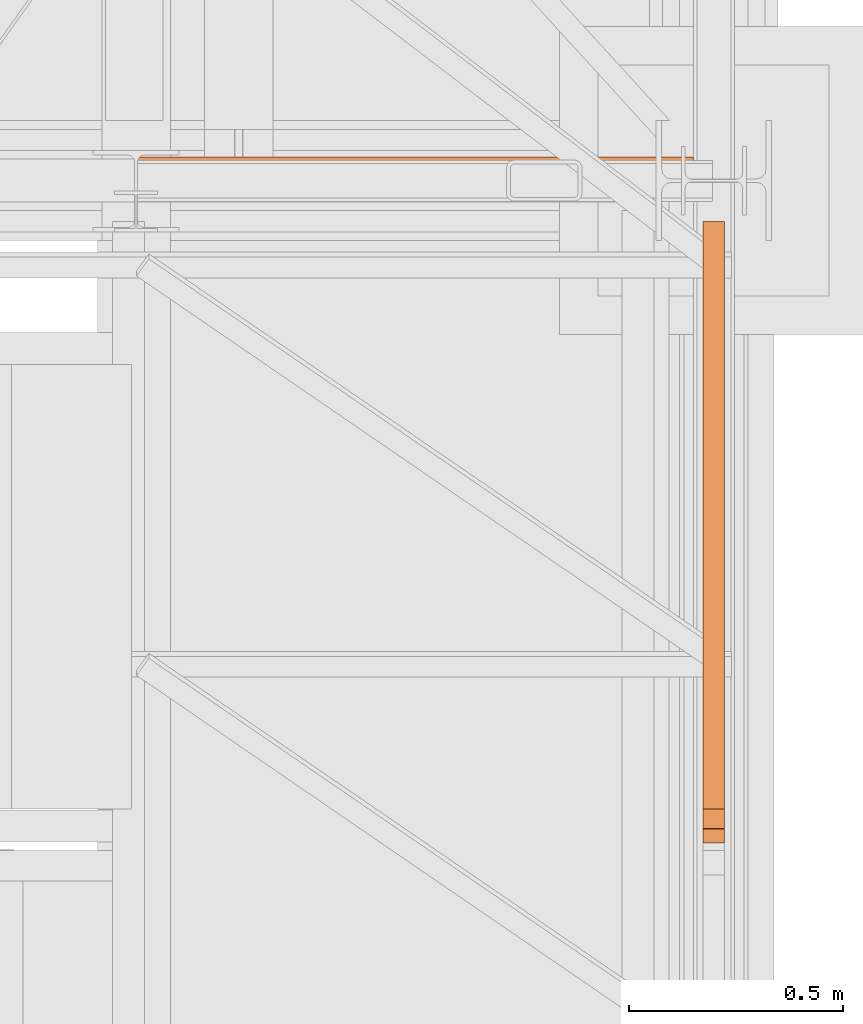
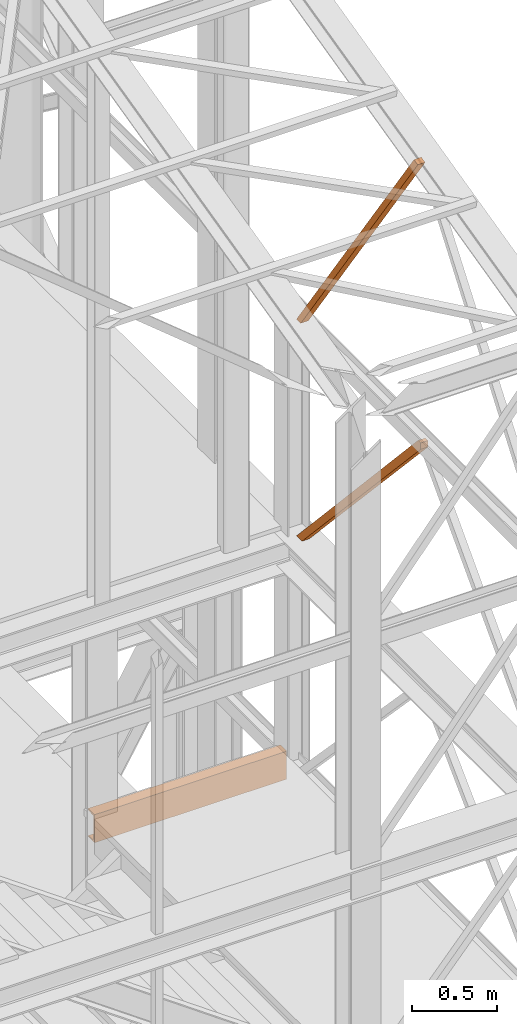
# One storey, part 59 of 208: 4 proxies.
"""IFC2X3 building model written with IfcOpenShell, lengths in millimetres."""

from ifc_helpers import new_model, entity, si_unit, converted_unit, frame, origin, origin_with_axes, place, context, subcontext, project, spatial, faceted_brep, element, save


model = new_model("IFC2X3")

# Units and contexts
model_context = context("Model", 3, precision=1e-05, world=origin())
plan_context = context("Plan", 3, precision=1e-05, world=origin())
body_context = subcontext(model_context, "Body", "Model", "MODEL_VIEW")
ifc_project = project(units=[si_unit("LENGTHUNIT", "METRE", prefix="MILLI"), converted_unit("PLANEANGLEUNIT", "DEGREE", entity("IfcPlaneAngleMeasure", 0.0174532925199433), si_unit("PLANEANGLEUNIT", "RADIAN"), dimensions=[0, 0, 0, 0, 0, 0, 0]), si_unit("AREAUNIT", "SQUARE_METRE"), si_unit("VOLUMEUNIT", "CUBIC_METRE")], contexts=[model_context, plan_context])

# Building, storey
building_placement = place(None, origin())
building = spatial("IfcBuilding", under=ifc_project, at=building_placement, CompositionType="COMPLEX")
storey_placement = place(building_placement, origin_with_axes())
storey = spatial("IfcBuildingStorey", under=building, at=storey_placement, Name="Geschoss", CompositionType="ELEMENT")

# Proxies
proxy_1_placement = place(storey_placement, frame((5351.50496859572, -22082.72083116692, 6709.989998509885), z_axis=(0.0, 0.0, 1.0), x_axis=(1.0, 0.0, 0.0)))
element("IfcBuildingElementProxy", 1, at=proxy_1_placement, inside=storey, context=body_context, shape_type="Brep", body=[
    faceted_brep([(0.01000000000021828, 0.00999999999839929, 200.0100029802325), (0.01000000000021828, 0.00999999999839929, 0.01000000000021828), (0.01000000000021828, 75.01000111758549, 0.01000000000021828), (0.01000000000021828, 75.01000111758549, 2.97083092689536), (0.01000000000021828, 73.89400100171406, 7.368834147453526), (0.01000000000021828, 69.488472694753, 8.951724896431188), (0.01000000000021828, 19.09293180167515, 12.98336816787742), (0.01000000000021828, 13.35380079060633, 14.57858962774299), (0.01000000000021828, 9.500150026975462, 18.85888857603095), (0.01000000000021828, 8.510000461934396, 24.44674206733725), (0.01000000000021828, 8.510000461934396, 175.5732609128954), (0.01000000000021828, 9.500150026975462, 181.1611144042017), (0.01000000000021828, 13.35380079060633, 185.4414133524897), (0.01000000000021828, 19.09293180167515, 187.0366348123553), (0.01000000000021828, 69.488472694753, 191.0682780838015), (0.01000000000021828, 73.89400100171406, 192.6511688327792), (0.01000000000021828, 75.01000111758549, 197.0491720533373), (0.01000000000021828, 75.01000111758549, 200.0100029802325), (0.01000000000021828, 0.00999999999839929, 0.01000000000021828), (0.01000000000021828, 0.00999999999839929, 200.0100029802325), (1298.7599995485, 0.00999999999839929, 200.0100029802325), (1298.7599995485, 0.00999999999839929, 0.01000000000021828), (0.01000000000021828, 75.01000111758549, 0.01000000000021828), (0.01000000000021828, 0.00999999999839929, 0.01000000000021828), (1298.7599995485, 0.00999999999839929, 0.01000000000021828), (1298.7599995485, 75.01000111758549, 0.01000000000021828), (0.01000000000021828, 75.01000111758549, 2.97083092689536), (0.01000000000021828, 75.01000111758549, 0.01000000000021828), (1298.7599995485, 75.01000111758549, 0.01000000000021828), (1298.7599995485, 75.01000111758549, 2.97083092689536), (0.01000000000021828, 73.89400100171406, 7.368834147453526), (0.01000000000021828, 75.01000111758549, 2.97083092689536), (1298.7599995485, 75.01000111758549, 2.97083092689536), (1298.7599995485, 73.89400100171406, 7.368834147453526), (0.01000000000021828, 69.488472694753, 8.951724896431188), (0.01000000000021828, 73.89400100171406, 7.368834147453526), (1298.7599995485, 73.89400100171406, 7.368834147453526), (1298.7599995485, 69.488472694753, 8.951724896431188), (0.01000000000021828, 19.09293180167515, 12.98336816787742), (0.01000000000021828, 69.488472694753, 8.951724896431188), (1298.7599995485, 69.488472694753, 8.951724896431188), (1298.7599995485, 19.09293180167515, 12.98336816787742), (0.01000000000021828, 13.35380079060633, 14.57858962774299), (0.01000000000021828, 19.09293180167515, 12.98336816787742), (1298.7599995485, 19.09293180167515, 12.98336816787742), (1298.7599995485, 13.35380079060633, 14.57858962774299), (0.01000000000021828, 9.500150026975462, 18.85888857603095), (0.01000000000021828, 13.35380079060633, 14.57858962774299), (1298.7599995485, 13.35380079060633, 14.57858962774299), (1298.7599995485, 9.500150026975462, 18.85888857603095), (0.01000000000021828, 8.510000461934396, 24.44674206733725), (0.01000000000021828, 9.500150026975462, 18.85888857603095), (1298.7599995485, 9.500150026975462, 18.85888857603095), (1298.7599995485, 8.510000461934396, 24.44674206733725), (0.01000000000021828, 8.510000461934396, 175.5732609128954), (0.01000000000021828, 8.510000461934396, 24.44674206733725), (1298.7599995485, 8.510000461934396, 24.44674206733725), (1298.7599995485, 8.510000461934396, 175.5732609128954), (0.01000000000021828, 9.500150026975462, 181.1611144042017), (0.01000000000021828, 8.510000461934396, 175.5732609128954), (1298.7599995485, 8.510000461934396, 175.5732609128954), (1298.7599995485, 9.500150026975462, 181.1611144042017), (0.01000000000021828, 13.35380079060633, 185.4414133524897), (0.01000000000021828, 9.500150026975462, 181.1611144042017), (1298.7599995485, 9.500150026975462, 181.1611144042017), (1298.7599995485, 13.35380079060633, 185.4414133524897), (0.01000000000021828, 19.09293180167515, 187.0366348123553), (0.01000000000021828, 13.35380079060633, 185.4414133524897), (1298.7599995485, 13.35380079060633, 185.4414133524897), (1298.7599995485, 19.09293180167515, 187.0366348123553), (0.01000000000021828, 69.488472694753, 191.0682780838015), (0.01000000000021828, 19.09293180167515, 187.0366348123553), (1298.7599995485, 19.09293180167515, 187.0366348123553), (1298.7599995485, 69.488472694753, 191.0682780838015), (0.01000000000021828, 73.89400100171406, 192.6511688327792), (0.01000000000021828, 69.488472694753, 191.0682780838015), (1298.7599995485, 69.488472694753, 191.0682780838015), (1298.7599995485, 73.89400100171406, 192.6511688327792), (0.01000000000021828, 75.01000111758549, 197.0491720533373), (0.01000000000021828, 73.89400100171406, 192.6511688327792), (1298.7599995485, 73.89400100171406, 192.6511688327792), (1298.7599995485, 75.01000111758549, 197.0491720533373), (0.01000000000021828, 75.01000111758549, 200.0100029802325), (0.01000000000021828, 75.01000111758549, 197.0491720533373), (1298.7599995485, 75.01000111758549, 197.0491720533373), (1298.7599995485, 75.01000111758549, 200.0100029802325), (0.01000000000021828, 0.00999999999839929, 200.0100029802325), (0.01000000000021828, 75.01000111758549, 200.0100029802325), (1298.7599995485, 75.01000111758549, 200.0100029802325), (1298.7599995485, 0.00999999999839929, 200.0100029802325), (1298.7599995485, 0.00999999999839929, 200.0100029802325), (1298.7599995485, 75.01000111758549, 200.0100029802325), (1298.7599995485, 75.01000111758549, 197.0491720533373), (1298.7599995485, 73.89400100171406, 192.6511688327792), (1298.7599995485, 69.488472694753, 191.0682780838015), (1298.7599995485, 19.09293180167515, 187.0366348123553), (1298.7599995485, 13.35380079060633, 185.4414133524897), (1298.7599995485, 9.500150026975462, 181.1611144042017), (1298.7599995485, 8.510000461934396, 175.5732609128954), (1298.7599995485, 8.510000461934396, 24.44674206733725), (1298.7599995485, 9.500150026975462, 18.85888857603095), (1298.7599995485, 13.35380079060633, 14.57858962774299), (1298.7599995485, 19.09293180167515, 12.98336816787742), (1298.7599995485, 69.488472694753, 8.951724896431188), (1298.7599995485, 73.89400100171406, 7.368834147453526), (1298.7599995485, 75.01000111758549, 2.97083092689536), (1298.7599995485, 75.01000111758549, 0.01000000000021828), (1298.7599995485, 0.00999999999839929, 0.01000000000021828)], [[[0, 1, 2, 3, 4, 5, 6, 7, 8, 9, 10, 11, 12, 13, 14, 15, 16, 17]], [[18, 19, 20, 21]], [[22, 23, 24, 25]], [[26, 27, 28, 29]], [[30, 31, 32, 33]], [[34, 35, 36, 37]], [[38, 39, 40, 41]], [[42, 43, 44, 45]], [[46, 47, 48, 49]], [[50, 51, 52, 53]], [[54, 55, 56, 57]], [[58, 59, 60, 61]], [[62, 63, 64, 65]], [[66, 67, 68, 69]], [[70, 71, 72, 73]], [[74, 75, 76, 77]], [[78, 79, 80, 81]], [[82, 83, 84, 85]], [[86, 87, 88, 89]], [[90, 91, 92, 93, 94, 95, 96, 97, 98, 99, 100, 101, 102, 103, 104, 105, 106, 107]]], orient=[[False], [False], [False], [False], [False], [False], [False], [False], [False], [False], [False], [False], [False], [False], [False], [False], [False], [False], [False], [False]]),
])
proxy_2_placement = place(storey_placement, frame((6673.254968156134, -23609.75807774477, 8484.990002086159), z_axis=(0.0, 0.0, 1.0), x_axis=(1.0, 0.0, 0.0)))
element("IfcBuildingElementProxy", 2, at=proxy_2_placement, inside=storey, context=body_context, shape_type="Brep", body=[
    faceted_brep([(0.01000000000112777, 0.00999999999839929, 1497.729951931144), (50.01000074505919, 0.00999999999839929, 1497.72995193114), (50.01000074505828, 1388.406277525959, 0.00999999999839929), (0.01000000000021828, 1388.406277525959, 0.00999999999839929), (50.01000074505919, 31.9146786755955, 1542.509998658894), (50.01000074505828, 1452.193689843443, 0.00999999999839929), (50.01000074505828, 1388.406277525959, 0.00999999999839929), (50.01000074505919, 0.00999999999839929, 1497.72995193114), (50.01000074505919, 0.1938854341788101, 1542.602553368595), (0.01000000000112777, 31.9146786755955, 1542.509998658894), (0.01000000000021828, 1452.193689843443, 0.00999999999839929), (50.01000074505828, 1452.193689843443, 0.00999999999839929), (50.01000074505919, 31.9146786755955, 1542.509998658894), (0.01000000000112777, 0.1938854341788101, 1542.602553368595), (0.01000000000112777, 0.00999999999839929, 1497.729951931144), (0.01000000000021828, 1388.406277525959, 0.00999999999839929), (0.01000000000021828, 1452.193689843443, 0.00999999999839929), (0.01000000000112777, 31.9146786755955, 1542.509998658894), (50.01000074505919, 0.1938854341788101, 1542.602553368595), (0.01000000000112777, 0.1938854341788101, 1542.602553368595), (0.01000000000112777, 31.9146786755955, 1542.509998658894), (50.01000074505919, 31.9146786755955, 1542.509998658894), (50.01000074505919, 0.00999999999839929, 1497.72995193114), (0.01000000000112777, 0.00999999999839929, 1497.729951931144), (0.01000000000112777, 0.1938854341788101, 1542.602553368595), (50.01000074505919, 0.1938854341788101, 1542.602553368595), (0.01000000000021828, 1388.406277525959, 0.00999999999839929), (50.01000074505828, 1388.406277525959, 0.00999999999839929), (50.01000074505828, 1452.193689843443, 0.00999999999839929), (0.01000000000021828, 1452.193689843443, 0.00999999999839929)], [[[0, 1, 2, 3]], [[4, 5, 6, 7, 8]], [[9, 10, 11, 12]], [[13, 14, 15, 16, 17]], [[18, 19, 20, 21]], [[22, 23, 24, 25]], [[26, 27, 28, 29]]], orient=[[False], [False], [False], [False], [False], [False], [False]]),
])
for number, where, z_axis, x_axis in (
    (3, (6673.254968156134, -23575.83452420606, 10032.49000074505), (0.0, 0.0, 1.0), (1.0, 0.0, 0.0)),
    (4, (6673.254968156134, -23575.83452420606, 10032.49000074505), (0.0, 0.0, 1.0), (1.0, 0.0, 0.0)),
):
    element("IfcBuildingElementProxy", number, at=place(storey_placement, frame(where, z_axis=z_axis, x_axis=x_axis)), inside=storey, context=body_context, shape_type="Brep", body=[
        faceted_brep([(50.0100007450601, 1418.270136304735, 0.00999999999839929), (50.01000074505828, 44.61965619294278, 1971.847245483068), (0.01000000000021828, 44.61965619294278, 1971.847245483068), (0.01000000000203727, 1418.270136304735, 0.00999999999839929), (50.0100007450601, 1368.278645494167, 0.00999999999839929), (50.01000074505828, 0.00999999999839929, 1961.019111489331), (50.01000074505828, 44.61965619294278, 1971.847245483068), (50.0100007450601, 1418.270136304735, 0.00999999999839929), (0.01000000000203727, 1368.278645494167, 0.00999999999839929), (0.01000000000021828, 0.00999999999839929, 1961.01911148933), (50.01000074505828, 0.00999999999839929, 1961.019111489331), (50.0100007450601, 1368.278645494167, 0.00999999999839929), (0.01000000000203727, 1418.270136304735, 0.00999999999839929), (0.01000000000021828, 44.61965619294278, 1971.847245483068), (0.01000000000021828, 0.00999999999839929, 1961.01911148933), (0.01000000000203727, 1368.278645494167, 0.00999999999839929), (0.01000000000203727, 1418.270136304735, 0.00999999999839929), (0.01000000000203727, 1368.278645494167, 0.00999999999839929), (50.0100007450601, 1368.278645494167, 0.00999999999839929), (50.0100007450601, 1418.270136304735, 0.00999999999839929), (50.01000074505828, 44.61965619294278, 1971.847245483068), (50.01000074505828, 0.00999999999839929, 1961.019111489331), (0.01000000000021828, 0.00999999999839929, 1961.01911148933), (0.01000000000021828, 44.61965619294278, 1971.847245483068)], [[[0, 1, 2, 3]], [[4, 5, 6, 7]], [[8, 9, 10, 11]], [[12, 13, 14, 15]], [[16, 17, 18, 19]], [[20, 21, 22, 23]]], orient=[[False], [False], [False], [False], [False], [False]]),
    ])

save(model, "model.ifc")
